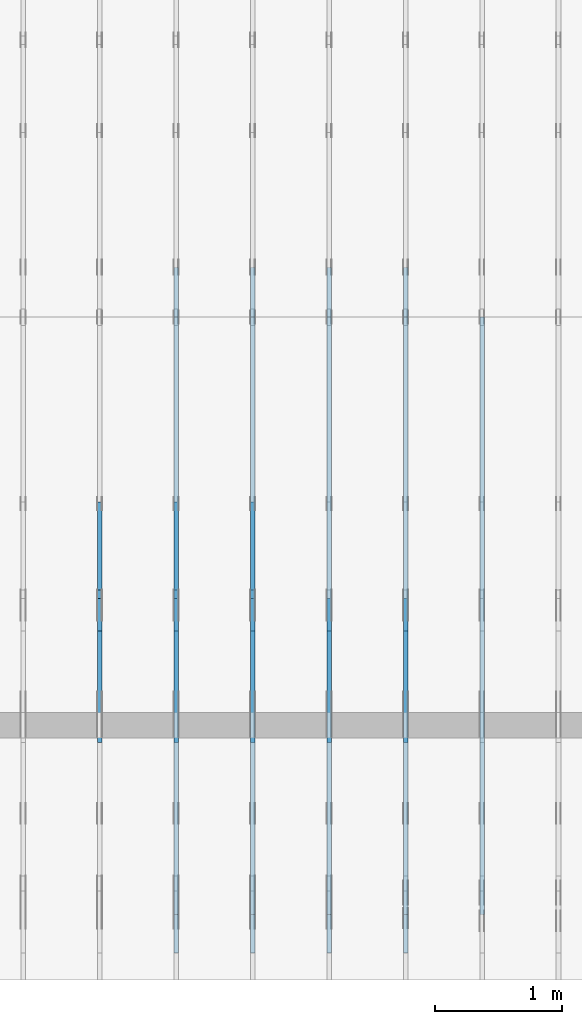
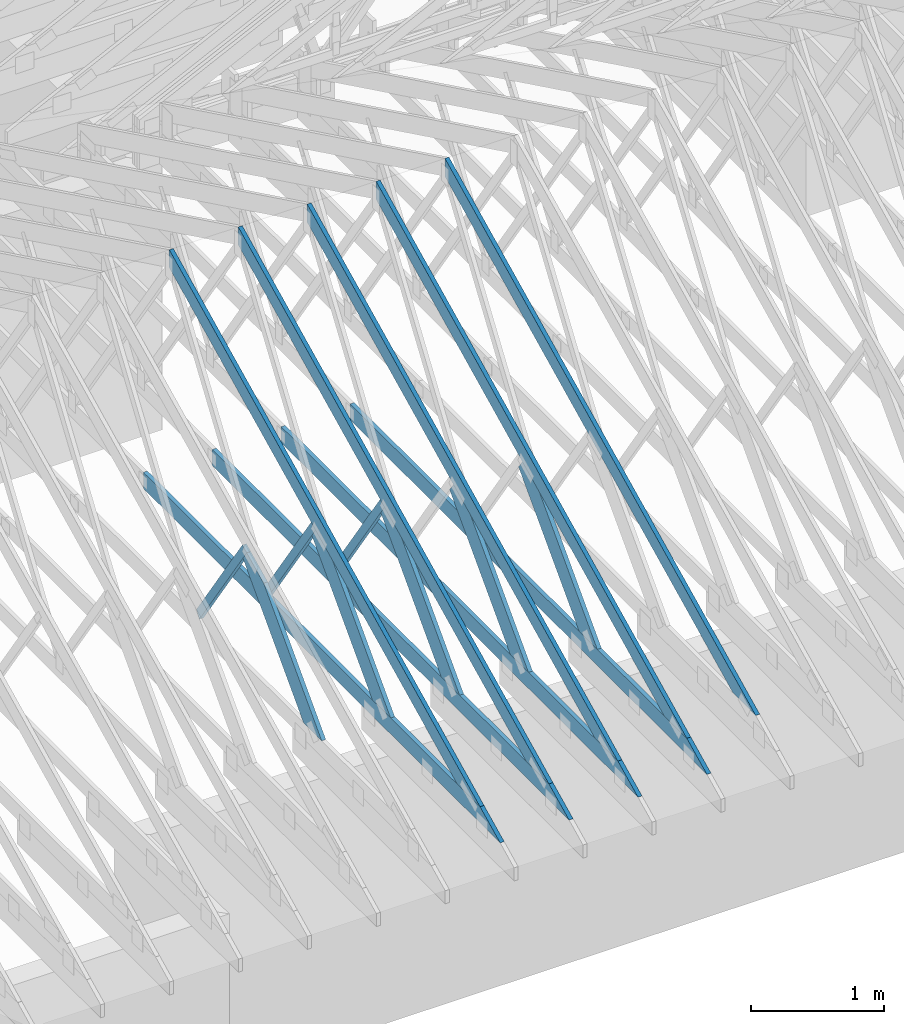
# One storey, part 12 of 159: 17 members, 6 elements without a shape of their own.
"""IFC2X3 building model written with IfcOpenShell, lengths in millimetres."""

import ifcopenshell
import ifcopenshell.guid

model = None  # the IFC model being written
_history = None  # IfcOwnerHistory: only IFC2X3 demands one
_inside = {}  # id of a spatial element -> (the spatial element, [elements in it])
_under = {}  # id of a project, library or spatial element -> (it, [spatial elements below it])
_declared = {}  # id of a project -> (the project, [libraries it declares])
_typed = {}  # id of a type object -> (the type object, [elements of that type])
_made_of = {}  # id of a material, layer set ... -> (it, [elements and type objects made of it])


def new_model(schema):
    """Start an empty IFC model of exactly this schema.

    Asked for "IFC4X3", IfcOpenShell would pick the latest addendum, in which some entities
    have other attributes; the version numbers below select the first issue.
    IFC2X3 requires an IfcOwnerHistory on every rooted entity: one is made here for all.
    """
    global model, _history
    if schema == "IFC4X3":
        model = ifcopenshell.file(schema_version=(4, 3, 0, 0))
    else:
        model = ifcopenshell.file(schema=schema)
    _inside.clear()
    _under.clear()
    _declared.clear()
    _typed.clear()
    _made_of.clear()
    _history = None
    if model.schema == "IFC2X3":
        org = make("IfcOrganization", Name="unknown")
        user = make(
            "IfcPersonAndOrganization",
            ThePerson=make("IfcPerson", FamilyName="unknown"),
            TheOrganization=org,
        )
        app = make(
            "IfcApplication",
            ApplicationDeveloper=org,
            Version="unknown",
            ApplicationFullName="unknown",
            ApplicationIdentifier="unknown",
        )
        _history = make(
            "IfcOwnerHistory",
            OwningUser=user,
            OwningApplication=app,
            ChangeAction="ADDED",
            CreationDate=0,
        )
    return model


def make(cls, **values):
    """One entity of the class cls with the attributes given. An attribute that is None is left unset."""
    return model.create_entity(
        cls, **{name: value for name, value in values.items() if value is not None}
    )


def rooted(cls, **values):
    """An entity with a GlobalId (a new one), such as an element, a storey or a relation."""
    return make(cls, GlobalId=ifcopenshell.guid.new(), OwnerHistory=_history, **values)


def si_unit(unit_type, name, prefix=None):
    """IfcSIUnit, for example si_unit("LENGTHUNIT", "METRE", prefix="MILLI")."""
    return make("IfcSIUnit", UnitType=unit_type, Prefix=prefix, Name=name)


def assignment(units):
    """IfcUnitAssignment: the units of a project."""
    return None if units is None else make("IfcUnitAssignment", Units=units)


def point(xyz):
    """IfcCartesianPoint."""
    return None if xyz is None else make("IfcCartesianPoint", Coordinates=xyz)


def direction(xyz):
    """IfcDirection."""
    return None if xyz is None else make("IfcDirection", DirectionRatios=xyz)


def frame(location, z_axis=None, x_axis=None):
    """IfcAxis2Placement3D, a coordinate frame: its origin and axes. An axis left out is left unset."""
    return make(
        "IfcAxis2Placement3D",
        Location=point(location),
        Axis=direction(z_axis),
        RefDirection=direction(x_axis),
    )


def frame_2d(location, x_axis=None):
    """IfcAxis2Placement2D, a coordinate frame in the plane: its origin and x axis."""
    return make(
        "IfcAxis2Placement2D", Location=point(location), RefDirection=direction(x_axis)
    )


def origin():
    """The frame at (0, 0, 0) with its axes left unset."""
    return frame((0.0, 0.0, 0.0))


def origin_with_axes():
    """The frame at (0, 0, 0) with the z axis (0, 0, 1) and the x axis (1, 0, 0) written out."""
    return frame((0.0, 0.0, 0.0), z_axis=(0.0, 0.0, 1.0), x_axis=(1.0, 0.0, 0.0))


def origin_2d():
    """The frame at (0, 0) in the plane with its x axis left unset."""
    return frame_2d((0.0, 0.0))


def place(relative_to, where):
    """IfcLocalPlacement: puts the frame where relative to a parent placement (None: the world)."""
    return make(
        "IfcLocalPlacement", PlacementRelTo=relative_to, RelativePlacement=where
    )


def context(
    kind, dimensions, precision=None, world=None, true_north=None, identifier=None
):
    """IfcGeometricRepresentationContext, for example the 3D "Model" context."""
    return make(
        "IfcGeometricRepresentationContext",
        ContextIdentifier=identifier,
        ContextType=kind,
        CoordinateSpaceDimension=dimensions,
        Precision=precision,
        WorldCoordinateSystem=world,
        TrueNorth=true_north,
    )


def project(units=None, contexts=None):
    """IfcProject with its units and contexts."""
    return rooted(
        "IfcProject",
        Name="project",
        RepresentationContexts=contexts,
        UnitsInContext=assignment(units),
    )


def spatial(cls, under=None, at=None, **own):
    """A site, building, storey or space (cls), placed at a placement, below another one or the project."""
    s = rooted(cls, ObjectPlacement=at, **own)
    if under is not None:
        _under.setdefault(under.id(), (under, []))[1].append(s)
    return s


def faces_of(points, faces, orient=None, outer=None):
    """IfcFace entities. A face is a list of loops; a loop is a list of indices into points, from 0.

    orient and outer hold one flag for each loop. By default every Orientation is true, the
    first loop of a face is its IfcFaceOuterBound and the others are IfcFaceBound.
    """
    made = []
    for i, loops in enumerate(faces):
        bounds = []
        for j, loop in enumerate(loops):
            is_outer = j == 0 if outer is None else outer[i][j]
            bounds.append(
                make(
                    "IfcFaceOuterBound" if is_outer else "IfcFaceBound",
                    Bound=make("IfcPolyLoop", Polygon=[points[k] for k in loop]),
                    Orientation=True if orient is None else orient[i][j],
                )
            )
        made.append(make("IfcFace", Bounds=bounds))
    return made


def faceted_brep(points, faces, orient=None, outer=None, voids=None):
    """IfcFacetedBrep: a solid bounded by flat faces; with voids (closed shells), ...WithVoids."""
    shared = [point(p) for p in points]
    hull = make("IfcClosedShell", CfsFaces=faces_of(shared, faces, orient, outer))
    if voids is None:
        return make("IfcFacetedBrep", Outer=hull)
    return make(
        "IfcFacetedBrepWithVoids",
        Outer=hull,
        Voids=[
            make(cls, CfsFaces=faces_of(shared, fs, o, b)) for cls, fs, o, b in voids
        ],
    )


def shape(context_of_items, identifier, shape_type, items):
    """IfcShapeRepresentation: the items that make up one representation, for example the "Body"."""
    return make(
        "IfcShapeRepresentation",
        ContextOfItems=context_of_items,
        RepresentationIdentifier=identifier,
        RepresentationType=shape_type,
        Items=items,
    )


def made_of(thing, what):
    """Note that an element or type object is made of a material, layer set ...; save() writes the relation."""
    if what is not None:
        _made_of.setdefault(what.id(), (what, []))[1].append(thing)
    return thing


def element(
    cls,
    number,
    at=None,
    inside=None,
    cuts=None,
    type_object=None,
    material=None,
    context=None,
    identifier="Body",
    shape_type=None,
    held_by="IfcProductDefinitionShape",
    body=None,
    shapes=None,
    **own,
):
    """One element of the class cls, such as IfcWall. Its Tag is "e" and its number.

    at: its placement. inside: the storey or other place that contains it. cuts: it is an
    opening in that element (IfcRelVoidsElement). A single representation is given by context,
    identifier, shape_type and body (its items); several are given by shapes. held_by: the class
    of the entity that holds the representations. save() writes the other relations.
    """
    e = rooted(cls, Tag="e%d" % number, ObjectPlacement=at, **own)
    if body is not None:
        shapes = [shape(context, identifier, shape_type, body)]
    if shapes is not None:
        e.Representation = make(held_by, Representations=shapes)
    if inside is not None:
        _inside.setdefault(inside.id(), (inside, []))[1].append(e)
    if cuts is not None:
        rooted(
            "IfcRelVoidsElement", RelatingBuildingElement=cuts, RelatedOpeningElement=e
        )
    if type_object is not None:
        _typed.setdefault(type_object.id(), (type_object, []))[1].append(e)
    return made_of(e, material)


def aggregate(whole, parts):
    """IfcRelAggregates: a whole, such as a stair, and the parts it consists of."""
    return rooted("IfcRelAggregates", RelatingObject=whole, RelatedObjects=parts)


def save(model, path):
    """Write the relations noted so far, then the file.

    IfcRelAggregates (storeys below a building ...), IfcRelContainedInSpatialStructure (elements
    in a storey), IfcRelDefinesByType, IfcRelAssociatesMaterial and IfcRelDeclares: one each for
    every whole, place, type object, material and project.
    """
    for whole, parts in _under.values():
        aggregate(whole, parts)
    for where, things in _inside.values():
        rooted(
            "IfcRelContainedInSpatialStructure",
            RelatedElements=things,
            RelatingStructure=where,
        )
    for kind, things in _typed.values():
        rooted("IfcRelDefinesByType", RelatedObjects=things, RelatingType=kind)
    for what, things in _made_of.values():
        rooted("IfcRelAssociatesMaterial", RelatedObjects=things, RelatingMaterial=what)
    for by, libraries in _declared.values():
        rooted("IfcRelDeclares", RelatingContext=by, RelatedDefinitions=libraries)
    model.write(path)


model = new_model("IFC2X3")

# Units and contexts
model_context = context("Model", 3, precision=1e-05, world=origin())
plan_context = context("Plan", 2, precision=1e-05, world=origin_2d())
ifc_project = project(units=[si_unit("LENGTHUNIT", "METRE", prefix="MILLI"), si_unit("AREAUNIT", "SQUARE_METRE"), si_unit("VOLUMEUNIT", "CUBIC_METRE"), si_unit("SOLIDANGLEUNIT", "STERADIAN"), si_unit("PLANEANGLEUNIT", "RADIAN"), si_unit("MASSUNIT", "GRAM"), si_unit("TIMEUNIT", "SECOND"), si_unit("THERMODYNAMICTEMPERATUREUNIT", "DEGREE_CELSIUS"), si_unit("LUMINOUSINTENSITYUNIT", "LUMEN")], contexts=[model_context, plan_context])

# Site, building, storey
site_placement = place(None, origin_with_axes())
site = spatial("IfcSite", under=ifc_project, at=site_placement, CompositionType="ELEMENT")
building_placement = place(site_placement, origin_with_axes())
building = spatial("IfcBuilding", under=site, at=building_placement, Name="Plan 1", CompositionType="ELEMENT")
storey_placement = place(building_placement, origin_with_axes())
storey = spatial("IfcBuildingStorey", under=building, at=storey_placement, Name="Etasje 1", CompositionType="ELEMENT", Elevation=0.0)

# Assembly, member
assembly_1_placement = place(storey_placement, frame((10875.02226140475, -699.9989301294845, 1.1021457184401395e-15), z_axis=(-1.0, 1.836909530733566e-16, 6.123031769111886e-17), x_axis=(-1.836909530733566e-16, -1.0, 0.0)))
assembly_1 = element("IfcElementAssembly", 1, at=assembly_1_placement, inside=storey, Name="T4 (96)", AssemblyPlace="FACTORY", PredefinedType="TRUSS")
member_1_placement = place(assembly_1_placement, frame((-5264.878447895178, 2523.1876964355156, -36.0), z_axis=(0.0, 0.0, 1.0), x_axis=(0.8987940462991668, -0.4383711467890778, 0.0)))
member_1 = element("IfcMember", 2, at=member_1_placement, Name="T4-O3", context=model_context, shape_type="Brep", body=[
    faceted_brep([(5212.95535395332, 148.00000154094027, 36.0), (0.0, 148.00000154094027, 36.0), (72.18440200989608, 5.7974317996922764e-05, 36.0), (4909.510382240189, 5.7974317996922764e-05, 36.0), (0.0, 148.00000154094027, 0.0), (5212.95535395332, 148.00000154094027, 6.383818248643616e-13), (4909.510382240189, 5.7974317996922764e-05, 6.012217608248263e-13), (72.18440200989608, 5.7974317996922764e-05, 8.839747734818752e-15), (72.18447769922204, 9.2140264804641e-06, -7.888609052210118e-31), (72.18447769922206, 9.2140264804641e-06, 36.0), (5.4591825588090614e-05, 148.00000921330525, 36.0), (5.4591825588090614e-05, 148.00000921330525, -7.888609052210118e-31), (4909.510401129447, 9.21290418597988e-06, 1.6550270895783706e-28), (4909.510401129447, 9.212904188184172e-06, 36.0), (72.18447769922204, 9.21402643937418e-06, 36.0), (72.18447769922204, 9.214026437169889e-06, 2.433384460947949e-30), (5212.955369681814, 148.00000921223887, 1.0605704288840677e-29), (5212.955369681814, 148.00000921223887, 36.0), (4909.510401129447, 9.212906661559828e-06, 36.0), (4909.510401129447, 9.212906661559828e-06, -1.359749288005947e-29), (5.459182557387976e-05, 148.00000921330525, 0.0), (5.459182557387976e-05, 148.00000921330525, 36.0), (5212.955369681813, 148.00000921223887, 36.0), (5212.955369681813, 148.00000921223887, 7.888609052210118e-30)], [[[0, 1, 2, 3]], [[4, 5, 6, 7]], [[8, 9, 10, 11]], [[12, 13, 14, 15]], [[16, 17, 18, 19]], [[20, 21, 22, 23]]]),
])
aggregate(assembly_1, [member_1])

# Assembly, members
assembly_2_placement = place(storey_placement, frame((10275.02226140475, -699.9989301294845, 1.1021457184401395e-15), z_axis=(-1.0, 1.836909530733566e-16, 6.123031769111886e-17), x_axis=(-1.836909530733566e-16, -1.0, 0.0)))
assembly_2 = element("IfcElementAssembly", 3, at=assembly_2_placement, inside=storey, Name="T3 (95)", AssemblyPlace="FACTORY", PredefinedType="TRUSS")
member_2_placement = place(assembly_2_placement, frame((-5264.878447895178, 2523.1876964355156, -36.0), z_axis=(0.0, 0.0, 1.0), x_axis=(0.8987940462991668, -0.4383711467890778, 0.0)))
member_2 = element("IfcMember", 4, at=member_2_placement, Name="T3-O3", context=model_context, shape_type="Brep", body=[
    faceted_brep([(5212.95535395332, 148.00000154094027, 36.0), (0.0, 148.00000154094027, 36.0), (72.18440200989608, 5.7974317996922764e-05, 36.0), (4909.510382240189, 5.7974317996922764e-05, 36.0), (0.0, 148.00000154094027, 0.0), (5212.95535395332, 148.00000154094027, 6.383818248643616e-13), (4909.510382240189, 5.7974317996922764e-05, 6.012217608248263e-13), (72.18440200989608, 5.7974317996922764e-05, 8.839747734818752e-15), (72.18447770003694, 9.212352093612708e-06, 0.0), (72.18447770003694, 9.212352093612708e-06, 36.0), (5.4591825616512324e-05, 148.00000921330522, 36.0), (5.4591825616512324e-05, 148.00000921330522, -2.3665827156630354e-30), (4909.510401129447, 9.212909786811436e-06, -1.878796081574631e-28), (4909.510401129447, 9.212909789015728e-06, 36.0), (72.18447770003695, 9.212352144484484e-06, 36.0), (72.18447770003695, 9.212352142280192e-06, -2.7623917880481857e-30), (5212.955369681814, 148.00000921223887, -1.46378446782317e-29), (5212.955369681814, 148.00000921223887, 36.0), (4909.510401129447, 9.212906661559828e-06, 36.0), (4909.510401129447, 9.212906661559828e-06, -1.359749288005947e-29), (5.459182557387976e-05, 148.00000921330525, 0.0), (5.459182557387976e-05, 148.00000921330525, 36.0), (5212.955369681813, 148.00000921223887, 36.0), (5212.955369681813, 148.00000921223887, 1.8932661725304283e-29)], [[[0, 1, 2, 3]], [[4, 5, 6, 7]], [[8, 9, 10, 11]], [[12, 13, 14, 15]], [[16, 17, 18, 19]], [[20, 21, 22, 23]]]),
])
member_3_placement = place(assembly_2_placement, frame((-211.18128967285153, 370.99999999999994, -36.0), z_axis=(0.0, 0.0, 1.0), x_axis=(-1.0, 1.2246063538223773e-16, 0.0)))
member_3 = element("IfcMember", 5, at=member_3_placement, Name="T3-U32", context=model_context, shape_type="Brep", body=[
    faceted_brep([(5379.999862670898, 148.00000000000063, 36.0), (0.0, 148.00000000000063, 36.0), (303.4449920654297, 0.0, 36.0), (5379.999862670898, 0.0, 36.0), (0.0, 148.00000000000063, 0.0), (5379.999862670898, 148.00000000000063, 6.588382015390299e-13), (5379.999862670898, 0.0, 6.588382015390299e-13), (303.4449920654297, 0.0, 3.7160066531890605e-14), (303.44497456355856, -8.526512829121202e-14, 1.178134630634113e-29), (303.44497456355856, -8.526512829121202e-14, 36.0), (6.009823252384194e-06, 148.00000000000014, 36.0), (6.009823252384194e-06, 148.00000000000014, -4.533241810344206e-30), (5380.000006009823, -8.745704909169925e-13, 6.051131019311846e-29), (5380.000006009823, -8.723661994801122e-13, 36.0), (303.4449745635586, 6.015103257559577e-14, 36.0), (303.4449745635586, 5.794674113871549e-14, 3.412983821904648e-30), (5380.000006009823, 148.00000000000009, 0.0), (5380.000006009823, 148.00000000000009, 36.0), (5380.000006009823, 1.1368683772161603e-13, 36.0), (5380.000006009823, 1.1368683772161603e-13, 0.0), (6.00982320975163e-06, 148.00000000000009, 0.0), (6.00982320975163e-06, 148.00000000000009, 36.0), (5380.000006009823, 147.99999999999974, 36.0), (5380.000006009823, 147.99999999999974, -2.0510383535746307e-29)], [[[0, 1, 2, 3]], [[4, 5, 6, 7]], [[8, 9, 10, 11]], [[12, 13, 14, 15]], [[16, 17, 18, 19]], [[20, 21, 22, 23]]]),
])
member_4_placement = place(assembly_2_placement, frame((-1862.2300707277423, 370.9999999999999, -36.0), z_axis=(0.0, 0.0, 1.0), x_axis=(-0.6895311389667145, 0.7242560378728407, 0.0)))
member_4 = element("IfcMember", 6, at=member_4_placement, Name="T3-D3", context=model_context, shape_type="Brep", body=[
    faceted_brep([(1514.7248164454636, 198.00009601649026, 36.0), (188.50674155347951, 198.00009601649026, 36.0), (2.1934896267339354e-05, 2.303954079252435e-05, 36.0), (1269.7672777270104, 2.303954079252435e-05, 36.0), (1535.8707840142733, 99.00001203843544, 36.0), (188.50674155347951, 198.00009601649026, 2.3084655344474377e-14), (1514.7248164454636, 198.00009601649026, 1.854941634511549e-13), (1535.8707840142733, 99.00001203843544, 1.8808371207540352e-13), (1269.7672777270104, 2.303954079252435e-05, 1.55496507618024e-13), (2.1934896267339354e-05, 2.303954079252435e-05, 2.686161333941852e-21), (0.0, 0.0, 0.0), (1.596471382391942e-15, -1.5199275850866338e-15, 36.0), (188.50676884433528, 198.00000000000043, 36.0), (188.50676884433528, 198.00000000000043, 1.5777218104420236e-30), (1269.7671934784398, 8.945350733394081e-13, 9.159828015255371e-31), (1269.7671934784398, 8.967393647762884e-13, 36.0), (-1.5528956900748675e-30, 2.204291436880279e-15, 36.0), (0.0, 0.0, 0.0), (1535.8707414831258, 99.00000000061334, 6.803309447121218e-29), (1535.8707414831258, 99.00000000061334, 36.0), (1269.7671934784403, 5.684341886080802e-14, 36.0), (1269.7671934784403, 5.684341886080802e-14, 5.62862243482568e-29), (1514.7247854919785, 197.99999999999926, -2.524354896707238e-29), (1514.7247854919785, 197.99999999999926, 36.0), (1535.870741483125, 99.00000000061434, 36.0), (1535.870741483125, 99.00000000061434, -1.262177448353619e-29), (188.50676884433528, 198.00000000000045, -1.5777218104420236e-30), (188.50676884433528, 198.00000000000045, 36.0), (1514.7247854919788, 197.99999999999918, 36.0), (1514.7247854919788, 197.99999999999918, -9.466330862652142e-30)], [[[0, 1, 2, 3, 4]], [[5, 6, 7, 8, 9]], [[10, 11, 12, 13]], [[14, 15, 16, 17]], [[18, 19, 20, 21]], [[22, 23, 24, 25]], [[26, 27, 28, 29]]]),
])
aggregate(assembly_2, [member_2, member_3, member_4])

assembly_3_placement = place(storey_placement, frame((9675.022261404752, 9699.99999999999, 1.1021457184401395e-15), z_axis=(-1.0, 1.836909530733566e-16, 6.123031769111886e-17), x_axis=(-1.836909530733566e-16, -1.0, 0.0)))
assembly_3 = element("IfcElementAssembly", 7, at=assembly_3_placement, inside=storey, Name="T2 (94)", AssemblyPlace="FACTORY", PredefinedType="TRUSS")
member_5_placement = place(assembly_3_placement, frame((5135.120455399391, 2523.187516882459, -36.0), z_axis=(0.0, 0.0, 1.0), x_axis=(0.8987940462991668, -0.4383711467890778, 0.0)))
member_5 = element("IfcMember", 8, at=member_5_placement, Name="T2-O3", context=model_context, shape_type="Brep", body=[
    faceted_brep([(5212.955657516367, 148.00034936960947, 36.0), (2.9272871415741974e-05, 148.00034936960947, 36.0), (72.18443128276795, 0.00027202273031434743, 36.0), (4909.50997264878, 0.00027202273031434743, 36.0), (2.9272871415741974e-05, 148.00034936960947, 3.584774433034307e-21), (5212.955657516367, 148.00034936960947, 6.383818620388851e-13), (4909.50997264878, 0.00027202273031434743, 6.012217106660022e-13), (72.18443128276795, 0.00027202273031434743, 8.83975131959324e-15), (72.18442310739601, 0.00018235889274720307, -7.888609052210118e-31), (72.18442310739601, 0.00018235889274720307, 36.0), (2.842170943040401e-14, 148.00018235817151, 36.0), (2.842170943040401e-14, 148.00018235817151, -2.3665827156630354e-30), (4909.510346538232, 0.0001823580668906902, 2.246999438374223e-28), (4909.510346538232, 0.0001823580668928945, 36.0), (72.18442310739601, 0.00018235889269189838, 36.0), (72.18442310739601, 0.0001823588926896941, 3.303759786827862e-30), (5212.955315092269, 148.00018235821926, -2.524354896707238e-29), (5212.955315092269, 148.00018235821926, 36.0), (4909.51034653823, 0.00018235807056043996, 36.0), (4909.51034653823, 0.00018235807056043996, -2.524354896707238e-29), (0.0, 148.00018235817151, 0.0), (0.0, 148.00018235817151, 36.0), (5212.95531509227, 148.00018235821864, 36.0), (5212.95531509227, 148.00018235821867, -1.1044052673094165e-29)], [[[0, 1, 2, 3]], [[4, 5, 6, 7]], [[8, 9, 10, 11]], [[12, 13, 14, 15]], [[16, 17, 18, 19]], [[20, 21, 22, 23]]]),
])
member_6_placement = place(assembly_3_placement, frame((10188.817634446803, 370.99999999999994, -36.0), z_axis=(0.0, 0.0, 1.0), x_axis=(-1.0, 1.2246063538223773e-16, 0.0)))
member_6 = element("IfcMember", 9, at=member_6_placement, Name="T2-U32", context=model_context, shape_type="Brep", body=[
    faceted_brep([(5379.999763353053, 148.0000000000006, 36.0), (0.00025163430291286204, 148.0000000000006, 36.0), (303.4445875718029, 0.0, 36.0), (5379.999763353053, 0.0, 36.0), (0.00025163430291286204, 148.0000000000006, 3.081529661867556e-20), (5379.999763353053, 148.0000000000006, 6.588381893765035e-13), (5379.999763353053, 0.0, 6.588381893765035e-13), (303.4445875718029, 0.0, 3.716001699734406e-14), (303.4449685537348, 1.2789769243681803e-13, -3.99587178143416e-30), (303.4449685537348, 1.2789769243681803e-13, 36.0), (7.105427357601002e-15, 148.00000000000009, 36.0), (7.105427357601002e-15, 148.00000000000009, -2.9555199832572376e-30), (5380.0, -8.745704898130424e-13, 6.051131012552325e-29), (5380.0, -8.723661983761621e-13, 36.0), (303.4449685537347, 6.015103367954605e-14, 36.0), (303.4449685537347, 5.794674224266577e-14, 3.4129837543094226e-30), (5380.0, 148.00000000000006, 0.0), (5380.0, 148.00000000000006, 36.0), (5380.0, 1.1368683772161603e-13, 36.0), (5380.0, 1.1368683772161603e-13, 0.0), (0.0, 148.00000000000006, 0.0), (-1.3496946496399237e-31, 148.00000000000006, 36.0), (5380.0, 147.99999999999972, 36.0), (5380.0, 147.99999999999972, -2.0510383535746307e-29)], [[[0, 1, 2, 3]], [[4, 5, 6, 7]], [[8, 9, 10, 11]], [[12, 13, 14, 15]], [[16, 17, 18, 19]], [[20, 21, 22, 23]]]),
])
member_7_placement = place(assembly_3_placement, frame((7335.335212521153, 1346.8364569956243, -36.0), z_axis=(0.0, 0.0, 1.0), x_axis=(0.6895311389452021, -0.7242560378933215, 0.0)))
member_7 = element("IfcMember", 10, at=member_7_placement, Name="T2-D3", context=model_context, shape_type="Brep", body=[
    faceted_brep([(1535.8706779051545, 197.99998461177984, 36.0), (266.10350628432207, 197.99998461177984, 36.0), (0.0, 99.00008397742658, 36.0), (21.14596757174968, 0.0, 36.0), (1347.3640424637342, 0.0, 36.0), (266.10350628432207, 197.99998461177984, 3.258720445701937e-14), (1535.8706779051545, 197.99998461177984, 1.880836990812134e-13), (1347.3640424637342, 0.0, 1.6499905673128923e-13), (21.14596757174968, 0.0, 2.5895486246086602e-15), (0.0, 99.00008397742658, 0.0), (0.00014664980380274528, 99.00020530045005, 1.5777218104420236e-30), (0.00014664980380274528, 99.00020530045005, 36.0), (266.10369462794824, 198.00020530010084, 36.0), (266.10369462794824, 198.00020530010084, 3.1554436208840472e-30), (21.146100291866794, 0.00020530010078800842, -2.0402049895968374e-31), (21.146100291866798, 0.0002053001007888966, 36.0), (0.00014664980384182513, 99.00020530045008, 36.0), (0.00014664980383827242, 99.00020530045008, -2.2174136190568693e-30), (1347.3641191793167, 0.00020530010172270798, -1.543300326584409e-30), (1347.3641191793167, 0.00020530010172491227, 36.0), (21.146100291866787, 0.00020530010079060828, 36.0), (21.146100291866787, 0.000205300100788404, -2.4221578316207596e-32), (1535.8708880124423, 198.00020530010443, 1.262177448353619e-29), (1535.8708880124423, 198.00020530010443, 36.0), (1347.364119179317, 0.00020530010181118996, 36.0), (1347.364119179317, 0.00020530010181118996, 1.262177448353619e-29), (266.10369462794824, 198.00020530010084, 1.5777218104420236e-30), (266.10369462794824, 198.00020530010082, 36.0), (1535.8708880124425, 198.0002053001047, 36.0), (1535.8708880124425, 198.0002053001047, 1.735493991486226e-29)], [[[0, 1, 2, 3, 4]], [[5, 6, 7, 8, 9]], [[10, 11, 12, 13]], [[14, 15, 16, 17]], [[18, 19, 20, 21]], [[22, 23, 24, 25]], [[26, 27, 28, 29]]]),
])
aggregate(assembly_3, [member_5, member_6, member_7])

assembly_4_placement = place(storey_placement, frame((9075.022261404752, 9699.99999999999, 1.1021457184401395e-15), z_axis=(-1.0, 1.836909530733566e-16, 6.123031769111886e-17), x_axis=(-1.836909530733566e-16, -1.0, 0.0)))
assembly_4 = element("IfcElementAssembly", 11, at=assembly_4_placement, inside=storey, Name="T2 (93)", AssemblyPlace="FACTORY", PredefinedType="TRUSS")
member_8_placement = place(assembly_4_placement, frame((5135.120455399391, 2523.187516882459, -36.0), z_axis=(0.0, 0.0, 1.0), x_axis=(0.8987940462991668, -0.4383711467890778, 0.0)))
member_8 = element("IfcMember", 12, at=member_8_placement, Name="T2-O3", context=model_context, shape_type="Brep", body=[
    faceted_brep([(5212.955657516367, 148.00034936960947, 36.0), (2.9272871415741974e-05, 148.00034936960947, 36.0), (72.18443128276795, 0.00027202273031434743, 36.0), (4909.50997264878, 0.00027202273031434743, 36.0), (2.9272871415741974e-05, 148.00034936960947, 3.584774433034307e-21), (5212.955657516367, 148.00034936960947, 6.383818620388851e-13), (4909.50997264878, 0.00027202273031434743, 6.012217106660022e-13), (72.18443128276795, 0.00027202273031434743, 8.83975131959324e-15), (72.18442310739601, 0.00018235889274720307, -7.888609052210118e-31), (72.18442310739601, 0.00018235889274720307, 36.0), (2.842170943040401e-14, 148.00018235817151, 36.0), (2.842170943040401e-14, 148.00018235817151, -2.3665827156630354e-30), (4909.510346538232, 0.0001823580668906902, 2.246999438374223e-28), (4909.510346538232, 0.0001823580668928945, 36.0), (72.18442310739601, 0.00018235889269189838, 36.0), (72.18442310739601, 0.0001823588926896941, 3.303759786827862e-30), (5212.955315092269, 148.00018235821926, -2.524354896707238e-29), (5212.955315092269, 148.00018235821926, 36.0), (4909.51034653823, 0.00018235807056043996, 36.0), (4909.51034653823, 0.00018235807056043996, -2.524354896707238e-29), (0.0, 148.00018235817151, 0.0), (0.0, 148.00018235817151, 36.0), (5212.95531509227, 148.00018235821864, 36.0), (5212.95531509227, 148.00018235821867, -1.1044052673094165e-29)], [[[0, 1, 2, 3]], [[4, 5, 6, 7]], [[8, 9, 10, 11]], [[12, 13, 14, 15]], [[16, 17, 18, 19]], [[20, 21, 22, 23]]]),
])
member_9_placement = place(assembly_4_placement, frame((10188.817634446803, 370.99999999999994, -36.0), z_axis=(0.0, 0.0, 1.0), x_axis=(-1.0, 1.2246063538223773e-16, 0.0)))
member_9 = element("IfcMember", 13, at=member_9_placement, Name="T2-U32", context=model_context, shape_type="Brep", body=[
    faceted_brep([(5379.999763353053, 148.0000000000006, 36.0), (0.00025163430291286204, 148.0000000000006, 36.0), (303.4445875718029, 0.0, 36.0), (5379.999763353053, 0.0, 36.0), (0.00025163430291286204, 148.0000000000006, 3.081529661867556e-20), (5379.999763353053, 148.0000000000006, 6.588381893765035e-13), (5379.999763353053, 0.0, 6.588381893765035e-13), (303.4445875718029, 0.0, 3.716001699734406e-14), (303.4449685537348, 1.2789769243681803e-13, -3.99587178143416e-30), (303.4449685537348, 1.2789769243681803e-13, 36.0), (7.105427357601002e-15, 148.00000000000009, 36.0), (7.105427357601002e-15, 148.00000000000009, -2.9555199832572376e-30), (5380.0, -8.745704898130424e-13, 6.051131012552325e-29), (5380.0, -8.723661983761621e-13, 36.0), (303.4449685537347, 6.015103367954605e-14, 36.0), (303.4449685537347, 5.794674224266577e-14, 3.4129837543094226e-30), (5380.0, 148.00000000000006, 0.0), (5380.0, 148.00000000000006, 36.0), (5380.0, 1.1368683772161603e-13, 36.0), (5380.0, 1.1368683772161603e-13, 0.0), (0.0, 148.00000000000006, 0.0), (-1.3496946496399237e-31, 148.00000000000006, 36.0), (5380.0, 147.99999999999972, 36.0), (5380.0, 147.99999999999972, -2.0510383535746307e-29)], [[[0, 1, 2, 3]], [[4, 5, 6, 7]], [[8, 9, 10, 11]], [[12, 13, 14, 15]], [[16, 17, 18, 19]], [[20, 21, 22, 23]]]),
])
member_10_placement = place(assembly_4_placement, frame((7346.76744651809, 1456.2902443153225, -36.0), z_axis=(0.0, 0.0, 1.0), x_axis=(-0.564247505007227, -0.8256056886269131, 0.0)))
member_10 = element("IfcMember", 14, at=member_10_placement, Name="T2-D42", context=model_context, shape_type="Brep", body=[
    faceted_brep([(1264.6472651905533, 73.00035481239047, 36.0), (8.801394596957834e-05, 73.00035481239047, 36.0), (10.714742691707215, 0.0, 36.0), (1236.1859046261452, 0.0, 36.0), (8.801394596957834e-05, 73.00035481239047, 1.0778243745932505e-20), (1264.6472651905533, 73.00035481239047, 1.5486950762964446e-13), (1236.1859046261452, 0.0, 1.5138411133108407e-13), (10.714742691707215, 0.0, 1.3121341979836537e-15), (10.714685884831852, 0.0001796189581002583, -9.62105002194463e-32), (10.714685884831855, 0.00017961895810048034, 36.0), (-2.6645352591003757e-14, 73.0001796189581, 36.0), (-2.842170943040401e-14, 73.0001796189581, 1.7622623733601546e-30), (1236.1860298817128, 0.00017961895895500981, 5.902699630823587e-29), (1236.1860298817128, 0.0001796189589572141, 36.0), (10.714685884831852, 0.0001796189580938849, 36.0), (10.714685884831852, 0.0001796189580916806, 5.1161877582816205e-31), (1264.6473849238073, 73.00017961895986, 0.0), (1264.6473849238073, 73.00017961895986, 36.0), (1236.1860298817128, 0.00017961895991902566, 36.0), (1236.1860298817128, 0.00017961895991902566, 0.0), (0.0, 73.0001796189581, 0.0), (0.0, 73.0001796189581, 36.0), (1264.6473849238073, 73.00017961895999, 36.0), (1264.6473849238073, 73.00017961895999, 4.733165431326071e-30)], [[[0, 1, 2, 3]], [[4, 5, 6, 7]], [[8, 9, 10, 11]], [[12, 13, 14, 15]], [[16, 17, 18, 19]], [[20, 21, 22, 23]]]),
])
member_11_placement = place(assembly_4_placement, frame((7335.335212521153, 1346.8364569956243, -36.0), z_axis=(0.0, 0.0, 1.0), x_axis=(0.6895311389452021, -0.7242560378933215, 0.0)))
member_11 = element("IfcMember", 15, at=member_11_placement, Name="T2-D3", context=model_context, shape_type="Brep", body=[
    faceted_brep([(1535.8706779051545, 197.99998461177984, 36.0), (266.10350628432207, 197.99998461177984, 36.0), (0.0, 99.00008397742658, 36.0), (21.14596757174968, 0.0, 36.0), (1347.3640424637342, 0.0, 36.0), (266.10350628432207, 197.99998461177984, 3.258720445701937e-14), (1535.8706779051545, 197.99998461177984, 1.880836990812134e-13), (1347.3640424637342, 0.0, 1.6499905673128923e-13), (21.14596757174968, 0.0, 2.5895486246086602e-15), (0.0, 99.00008397742658, 0.0), (0.00014664980380274528, 99.00020530045005, 1.5777218104420236e-30), (0.00014664980380274528, 99.00020530045005, 36.0), (266.10369462794824, 198.00020530010084, 36.0), (266.10369462794824, 198.00020530010084, 3.1554436208840472e-30), (21.146100291866794, 0.00020530010078800842, -2.0402049895968374e-31), (21.146100291866798, 0.0002053001007888966, 36.0), (0.00014664980384182513, 99.00020530045008, 36.0), (0.00014664980383827242, 99.00020530045008, -2.2174136190568693e-30), (1347.3641191793167, 0.00020530010172270798, -1.543300326584409e-30), (1347.3641191793167, 0.00020530010172491227, 36.0), (21.146100291866787, 0.00020530010079060828, 36.0), (21.146100291866787, 0.000205300100788404, -2.4221578316207596e-32), (1535.8708880124423, 198.00020530010443, 1.262177448353619e-29), (1535.8708880124423, 198.00020530010443, 36.0), (1347.364119179317, 0.00020530010181118996, 36.0), (1347.364119179317, 0.00020530010181118996, 1.262177448353619e-29), (266.10369462794824, 198.00020530010084, 1.5777218104420236e-30), (266.10369462794824, 198.00020530010082, 36.0), (1535.8708880124425, 198.0002053001047, 36.0), (1535.8708880124425, 198.0002053001047, 1.735493991486226e-29)], [[[0, 1, 2, 3, 4]], [[5, 6, 7, 8, 9]], [[10, 11, 12, 13]], [[14, 15, 16, 17]], [[18, 19, 20, 21]], [[22, 23, 24, 25]], [[26, 27, 28, 29]]]),
])
aggregate(assembly_4, [member_8, member_9, member_10, member_11])

assembly_5_placement = place(storey_placement, frame((8475.022261404752, 9699.99999999999, 1.1021457184401395e-15), z_axis=(-1.0, 1.836909530733566e-16, 6.123031769111886e-17), x_axis=(-1.836909530733566e-16, -1.0, 0.0)))
assembly_5 = element("IfcElementAssembly", 16, at=assembly_5_placement, inside=storey, Name="T2 (92)", AssemblyPlace="FACTORY", PredefinedType="TRUSS")
member_12_placement = place(assembly_5_placement, frame((5135.120455399391, 2523.187516882459, -36.0), z_axis=(0.0, 0.0, 1.0), x_axis=(0.8987940462991668, -0.4383711467890778, 0.0)))
member_12 = element("IfcMember", 17, at=member_12_placement, Name="T2-O3", context=model_context, shape_type="Brep", body=[
    faceted_brep([(5212.955657516367, 148.00034936960947, 36.0), (2.9272871415741974e-05, 148.00034936960947, 36.0), (72.18443128276795, 0.00027202273031434743, 36.0), (4909.50997264878, 0.00027202273031434743, 36.0), (2.9272871415741974e-05, 148.00034936960947, 3.584774433034307e-21), (5212.955657516367, 148.00034936960947, 6.383818620388851e-13), (4909.50997264878, 0.00027202273031434743, 6.012217106660022e-13), (72.18443128276795, 0.00027202273031434743, 8.83975131959324e-15), (72.18442310739601, 0.00018235889274720307, -7.888609052210118e-31), (72.18442310739601, 0.00018235889274720307, 36.0), (2.842170943040401e-14, 148.00018235817151, 36.0), (2.842170943040401e-14, 148.00018235817151, -2.3665827156630354e-30), (4909.510346538232, 0.0001823580668906902, 2.246999438374223e-28), (4909.510346538232, 0.0001823580668928945, 36.0), (72.18442310739601, 0.00018235889269189838, 36.0), (72.18442310739601, 0.0001823588926896941, 3.303759786827862e-30), (5212.955315092269, 148.00018235821926, -2.524354896707238e-29), (5212.955315092269, 148.00018235821926, 36.0), (4909.51034653823, 0.00018235807056043996, 36.0), (4909.51034653823, 0.00018235807056043996, -2.524354896707238e-29), (0.0, 148.00018235817151, 0.0), (0.0, 148.00018235817151, 36.0), (5212.95531509227, 148.00018235821864, 36.0), (5212.95531509227, 148.00018235821867, -1.1044052673094165e-29)], [[[0, 1, 2, 3]], [[4, 5, 6, 7]], [[8, 9, 10, 11]], [[12, 13, 14, 15]], [[16, 17, 18, 19]], [[20, 21, 22, 23]]]),
])
member_13_placement = place(assembly_5_placement, frame((10188.817634446803, 370.99999999999994, -36.0), z_axis=(0.0, 0.0, 1.0), x_axis=(-1.0, 1.2246063538223773e-16, 0.0)))
member_13 = element("IfcMember", 18, at=member_13_placement, Name="T2-U32", context=model_context, shape_type="Brep", body=[
    faceted_brep([(5379.999763353053, 148.0000000000006, 36.0), (0.00025163430291286204, 148.0000000000006, 36.0), (303.4445875718029, 0.0, 36.0), (5379.999763353053, 0.0, 36.0), (0.00025163430291286204, 148.0000000000006, 3.081529661867556e-20), (5379.999763353053, 148.0000000000006, 6.588381893765035e-13), (5379.999763353053, 0.0, 6.588381893765035e-13), (303.4445875718029, 0.0, 3.716001699734406e-14), (303.4449685537348, 1.2789769243681803e-13, -3.99587178143416e-30), (303.4449685537348, 1.2789769243681803e-13, 36.0), (7.105427357601002e-15, 148.00000000000009, 36.0), (7.105427357601002e-15, 148.00000000000009, -2.9555199832572376e-30), (5380.0, -8.745704898130424e-13, 6.051131012552325e-29), (5380.0, -8.723661983761621e-13, 36.0), (303.4449685537347, 6.015103367954605e-14, 36.0), (303.4449685537347, 5.794674224266577e-14, 3.4129837543094226e-30), (5380.0, 148.00000000000006, 0.0), (5380.0, 148.00000000000006, 36.0), (5380.0, 1.1368683772161603e-13, 36.0), (5380.0, 1.1368683772161603e-13, 0.0), (0.0, 148.00000000000006, 0.0), (-1.3496946496399237e-31, 148.00000000000006, 36.0), (5380.0, 147.99999999999972, 36.0), (5380.0, 147.99999999999972, -2.0510383535746307e-29)], [[[0, 1, 2, 3]], [[4, 5, 6, 7]], [[8, 9, 10, 11]], [[12, 13, 14, 15]], [[16, 17, 18, 19]], [[20, 21, 22, 23]]]),
])
member_14_placement = place(assembly_5_placement, frame((7346.76744651809, 1456.2902443153225, -36.0), z_axis=(0.0, 0.0, 1.0), x_axis=(-0.564247505007227, -0.8256056886269131, 0.0)))
member_14 = element("IfcMember", 19, at=member_14_placement, Name="T2-D42", context=model_context, shape_type="Brep", body=[
    faceted_brep([(1264.6472651905533, 73.00035481239047, 36.0), (8.801394596957834e-05, 73.00035481239047, 36.0), (10.714742691707215, 0.0, 36.0), (1236.1859046261452, 0.0, 36.0), (8.801394596957834e-05, 73.00035481239047, 1.0778243745932505e-20), (1264.6472651905533, 73.00035481239047, 1.5486950762964446e-13), (1236.1859046261452, 0.0, 1.5138411133108407e-13), (10.714742691707215, 0.0, 1.3121341979836537e-15), (10.714685884831852, 0.0001796189581002583, -9.62105002194463e-32), (10.714685884831855, 0.00017961895810048034, 36.0), (-2.6645352591003757e-14, 73.0001796189581, 36.0), (-2.842170943040401e-14, 73.0001796189581, 1.7622623733601546e-30), (1236.1860298817128, 0.00017961895895500981, 5.902699630823587e-29), (1236.1860298817128, 0.0001796189589572141, 36.0), (10.714685884831852, 0.0001796189580938849, 36.0), (10.714685884831852, 0.0001796189580916806, 5.1161877582816205e-31), (1264.6473849238073, 73.00017961895986, 0.0), (1264.6473849238073, 73.00017961895986, 36.0), (1236.1860298817128, 0.00017961895991902566, 36.0), (1236.1860298817128, 0.00017961895991902566, 0.0), (0.0, 73.0001796189581, 0.0), (0.0, 73.0001796189581, 36.0), (1264.6473849238073, 73.00017961895999, 36.0), (1264.6473849238073, 73.00017961895999, 4.733165431326071e-30)], [[[0, 1, 2, 3]], [[4, 5, 6, 7]], [[8, 9, 10, 11]], [[12, 13, 14, 15]], [[16, 17, 18, 19]], [[20, 21, 22, 23]]]),
])
member_15_placement = place(assembly_5_placement, frame((7335.335212521153, 1346.8364569956243, -36.0), z_axis=(0.0, 0.0, 1.0), x_axis=(0.6895311389452021, -0.7242560378933215, 0.0)))
member_15 = element("IfcMember", 20, at=member_15_placement, Name="T2-D3", context=model_context, shape_type="Brep", body=[
    faceted_brep([(1535.8706779051545, 197.99998461177984, 36.0), (266.10350628432207, 197.99998461177984, 36.0), (0.0, 99.00008397742658, 36.0), (21.14596757174968, 0.0, 36.0), (1347.3640424637342, 0.0, 36.0), (266.10350628432207, 197.99998461177984, 3.258720445701937e-14), (1535.8706779051545, 197.99998461177984, 1.880836990812134e-13), (1347.3640424637342, 0.0, 1.6499905673128923e-13), (21.14596757174968, 0.0, 2.5895486246086602e-15), (0.0, 99.00008397742658, 0.0), (0.00014664980380274528, 99.00020530045005, 1.5777218104420236e-30), (0.00014664980380274528, 99.00020530045005, 36.0), (266.10369462794824, 198.00020530010084, 36.0), (266.10369462794824, 198.00020530010084, 3.1554436208840472e-30), (21.146100291866794, 0.00020530010078800842, -2.0402049895968374e-31), (21.146100291866798, 0.0002053001007888966, 36.0), (0.00014664980384182513, 99.00020530045008, 36.0), (0.00014664980383827242, 99.00020530045008, -2.2174136190568693e-30), (1347.3641191793167, 0.00020530010172270798, -1.543300326584409e-30), (1347.3641191793167, 0.00020530010172491227, 36.0), (21.146100291866787, 0.00020530010079060828, 36.0), (21.146100291866787, 0.000205300100788404, -2.4221578316207596e-32), (1535.8708880124423, 198.00020530010443, 1.262177448353619e-29), (1535.8708880124423, 198.00020530010443, 36.0), (1347.364119179317, 0.00020530010181118996, 36.0), (1347.364119179317, 0.00020530010181118996, 1.262177448353619e-29), (266.10369462794824, 198.00020530010084, 1.5777218104420236e-30), (266.10369462794824, 198.00020530010082, 36.0), (1535.8708880124425, 198.0002053001047, 36.0), (1535.8708880124425, 198.0002053001047, 1.735493991486226e-29)], [[[0, 1, 2, 3, 4]], [[5, 6, 7, 8, 9]], [[10, 11, 12, 13]], [[14, 15, 16, 17]], [[18, 19, 20, 21]], [[22, 23, 24, 25]], [[26, 27, 28, 29]]]),
])
aggregate(assembly_5, [member_12, member_13, member_14, member_15])

assembly_6_placement = place(storey_placement, frame((7875.0222614047525, 9699.99999999999, 1.1021457184401395e-15), z_axis=(-1.0, 1.836909530733566e-16, 6.123031769111886e-17), x_axis=(-1.836909530733566e-16, -1.0, 0.0)))
assembly_6 = element("IfcElementAssembly", 21, at=assembly_6_placement, inside=storey, Name="T2 (91)", AssemblyPlace="FACTORY", PredefinedType="TRUSS")
member_16_placement = place(assembly_6_placement, frame((7346.76744651809, 1456.2902443153225, -36.0), z_axis=(0.0, 0.0, 1.0), x_axis=(-0.564247505007227, -0.8256056886269131, 0.0)))
member_16 = element("IfcMember", 22, at=member_16_placement, Name="T2-D42", context=model_context, shape_type="Brep", body=[
    faceted_brep([(1264.6472651905533, 73.00035481239047, 36.0), (8.801394596957834e-05, 73.00035481239047, 36.0), (10.714742691707215, 0.0, 36.0), (1236.1859046261452, 0.0, 36.0), (8.801394596957834e-05, 73.00035481239047, 1.0778243745932505e-20), (1264.6472651905533, 73.00035481239047, 1.5486950762964446e-13), (1236.1859046261452, 0.0, 1.5138411133108407e-13), (10.714742691707215, 0.0, 1.3121341979836537e-15), (10.714685884831852, 0.0001796189581002583, -9.62105002194463e-32), (10.714685884831855, 0.00017961895810048034, 36.0), (-2.6645352591003757e-14, 73.0001796189581, 36.0), (-2.842170943040401e-14, 73.0001796189581, 1.7622623733601546e-30), (1236.1860298817128, 0.00017961895895500981, 5.902699630823587e-29), (1236.1860298817128, 0.0001796189589572141, 36.0), (10.714685884831852, 0.0001796189580938849, 36.0), (10.714685884831852, 0.0001796189580916806, 5.1161877582816205e-31), (1264.6473849238073, 73.00017961895986, 0.0), (1264.6473849238073, 73.00017961895986, 36.0), (1236.1860298817128, 0.00017961895991902566, 36.0), (1236.1860298817128, 0.00017961895991902566, 0.0), (0.0, 73.0001796189581, 0.0), (0.0, 73.0001796189581, 36.0), (1264.6473849238073, 73.00017961895999, 36.0), (1264.6473849238073, 73.00017961895999, 4.733165431326071e-30)], [[[0, 1, 2, 3]], [[4, 5, 6, 7]], [[8, 9, 10, 11]], [[12, 13, 14, 15]], [[16, 17, 18, 19]], [[20, 21, 22, 23]]]),
])
member_17_placement = place(assembly_6_placement, frame((7335.335212521153, 1346.8364569956243, -36.0), z_axis=(0.0, 0.0, 1.0), x_axis=(0.6895311389452021, -0.7242560378933215, 0.0)))
member_17 = element("IfcMember", 23, at=member_17_placement, Name="T2-D3", context=model_context, shape_type="Brep", body=[
    faceted_brep([(1535.8706779051545, 197.99998461177984, 36.0), (266.10350628432207, 197.99998461177984, 36.0), (0.0, 99.00008397742658, 36.0), (21.14596757174968, 0.0, 36.0), (1347.3640424637342, 0.0, 36.0), (266.10350628432207, 197.99998461177984, 3.258720445701937e-14), (1535.8706779051545, 197.99998461177984, 1.880836990812134e-13), (1347.3640424637342, 0.0, 1.6499905673128923e-13), (21.14596757174968, 0.0, 2.5895486246086602e-15), (0.0, 99.00008397742658, 0.0), (0.00014664980380274528, 99.00020530045005, 1.5777218104420236e-30), (0.00014664980380274528, 99.00020530045005, 36.0), (266.10369462794824, 198.00020530010084, 36.0), (266.10369462794824, 198.00020530010084, 3.1554436208840472e-30), (21.146100291866794, 0.00020530010078800842, -2.0402049895968374e-31), (21.146100291866798, 0.0002053001007888966, 36.0), (0.00014664980384182513, 99.00020530045008, 36.0), (0.00014664980383827242, 99.00020530045008, -2.2174136190568693e-30), (1347.3641191793167, 0.00020530010172270798, -1.543300326584409e-30), (1347.3641191793167, 0.00020530010172491227, 36.0), (21.146100291866787, 0.00020530010079060828, 36.0), (21.146100291866787, 0.000205300100788404, -2.4221578316207596e-32), (1535.8708880124423, 198.00020530010443, 1.262177448353619e-29), (1535.8708880124423, 198.00020530010443, 36.0), (1347.364119179317, 0.00020530010181118996, 36.0), (1347.364119179317, 0.00020530010181118996, 1.262177448353619e-29), (266.10369462794824, 198.00020530010084, 1.5777218104420236e-30), (266.10369462794824, 198.00020530010082, 36.0), (1535.8708880124425, 198.0002053001047, 36.0), (1535.8708880124425, 198.0002053001047, 1.735493991486226e-29)], [[[0, 1, 2, 3, 4]], [[5, 6, 7, 8, 9]], [[10, 11, 12, 13]], [[14, 15, 16, 17]], [[18, 19, 20, 21]], [[22, 23, 24, 25]], [[26, 27, 28, 29]]]),
])
aggregate(assembly_6, [member_16, member_17])

save(model, "model.ifc")
